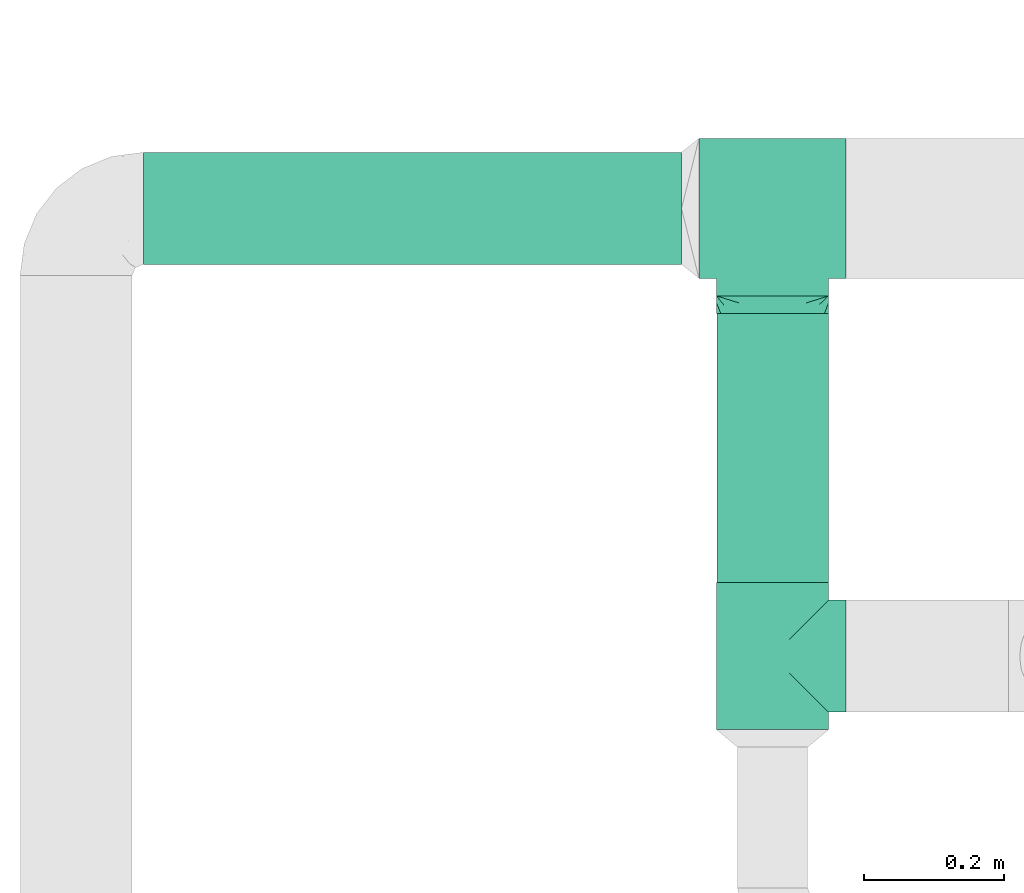
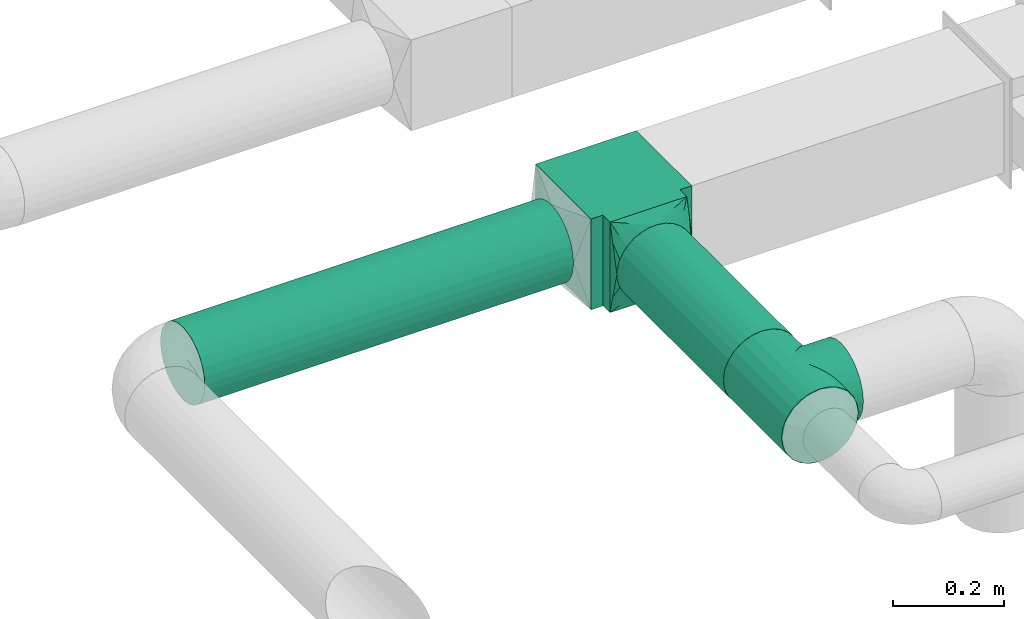
# One storey, part 4 of 12: 3 flow fittings, 2 flow segments.
"""IFC2X3 building model written with IfcOpenShell, lengths in millimetres."""

import ifcopenshell
import ifcopenshell.guid

model = None  # the IFC model being written
_history = None  # IfcOwnerHistory: only IFC2X3 demands one
_inside = {}  # id of a spatial element -> (the spatial element, [elements in it])
_under = {}  # id of a project, library or spatial element -> (it, [spatial elements below it])
_declared = {}  # id of a project -> (the project, [libraries it declares])
_typed = {}  # id of a type object -> (the type object, [elements of that type])
_made_of = {}  # id of a material, layer set ... -> (it, [elements and type objects made of it])


def new_model(schema):
    """Start an empty IFC model of exactly this schema.

    Asked for "IFC4X3", IfcOpenShell would pick the latest addendum, in which some entities
    have other attributes; the version numbers below select the first issue.
    IFC2X3 requires an IfcOwnerHistory on every rooted entity: one is made here for all.
    """
    global model, _history
    if schema == "IFC4X3":
        model = ifcopenshell.file(schema_version=(4, 3, 0, 0))
    else:
        model = ifcopenshell.file(schema=schema)
    _inside.clear()
    _under.clear()
    _declared.clear()
    _typed.clear()
    _made_of.clear()
    _history = None
    if model.schema == "IFC2X3":
        org = make("IfcOrganization", Name="unknown")
        user = make(
            "IfcPersonAndOrganization",
            ThePerson=make("IfcPerson", FamilyName="unknown"),
            TheOrganization=org,
        )
        app = make(
            "IfcApplication",
            ApplicationDeveloper=org,
            Version="unknown",
            ApplicationFullName="unknown",
            ApplicationIdentifier="unknown",
        )
        _history = make(
            "IfcOwnerHistory",
            OwningUser=user,
            OwningApplication=app,
            ChangeAction="ADDED",
            CreationDate=0,
        )
    return model


def make(cls, **values):
    """One entity of the class cls with the attributes given. An attribute that is None is left unset."""
    return model.create_entity(
        cls, **{name: value for name, value in values.items() if value is not None}
    )


def entity(cls, *values):
    """Any entity or typed value of the class cls, its attributes in the order of the schema. None: left unset."""
    e = model.create_entity(cls)
    for i, value in enumerate(values):
        if value is not None:
            e[i] = value
    return e


def rooted(cls, **values):
    """An entity with a GlobalId (a new one), such as an element, a storey or a relation."""
    return make(cls, GlobalId=ifcopenshell.guid.new(), OwnerHistory=_history, **values)


def si_unit(unit_type, name, prefix=None):
    """IfcSIUnit, for example si_unit("LENGTHUNIT", "METRE", prefix="MILLI")."""
    return make("IfcSIUnit", UnitType=unit_type, Prefix=prefix, Name=name)


def converted_unit(unit_type, name, factor, base, dimensions=None, offset=None):
    """IfcConversionBasedUnit, such as the inch: factor (a typed value) times the base unit."""
    return make(
        "IfcConversionBasedUnit"
        if offset is None
        else "IfcConversionBasedUnitWithOffset",
        ConversionOffset=offset,
        Dimensions=None
        if dimensions is None
        else entity("IfcDimensionalExponents", *dimensions),
        UnitType=unit_type,
        Name=name,
        ConversionFactor=make(
            "IfcMeasureWithUnit", ValueComponent=factor, UnitComponent=base
        ),
    )


def derived_unit(unit_type, elements):
    """IfcDerivedUnit: a product of units, each with its exponent."""
    return make(
        "IfcDerivedUnit",
        Elements=[
            make("IfcDerivedUnitElement", Unit=unit, Exponent=power)
            for unit, power in elements
        ],
        UnitType=unit_type,
    )


def assignment(units):
    """IfcUnitAssignment: the units of a project."""
    return None if units is None else make("IfcUnitAssignment", Units=units)


def point(xyz):
    """IfcCartesianPoint."""
    return None if xyz is None else make("IfcCartesianPoint", Coordinates=xyz)


def direction(xyz):
    """IfcDirection."""
    return None if xyz is None else make("IfcDirection", DirectionRatios=xyz)


def frame(location, z_axis=None, x_axis=None):
    """IfcAxis2Placement3D, a coordinate frame: its origin and axes. An axis left out is left unset."""
    return make(
        "IfcAxis2Placement3D",
        Location=point(location),
        Axis=direction(z_axis),
        RefDirection=direction(x_axis),
    )


def frame_2d(location, x_axis=None):
    """IfcAxis2Placement2D, a coordinate frame in the plane: its origin and x axis."""
    return make(
        "IfcAxis2Placement2D", Location=point(location), RefDirection=direction(x_axis)
    )


def origin():
    """The frame at (0, 0, 0) with its axes left unset."""
    return frame((0.0, 0.0, 0.0))


def origin_2d_with_axis():
    """The frame at (0, 0) in the plane with the x axis (1, 0) written out."""
    return frame_2d((0.0, 0.0), x_axis=(1.0, 0.0))


def place(relative_to, where):
    """IfcLocalPlacement: puts the frame where relative to a parent placement (None: the world)."""
    return make(
        "IfcLocalPlacement", PlacementRelTo=relative_to, RelativePlacement=where
    )


def context(
    kind, dimensions, precision=None, world=None, true_north=None, identifier=None
):
    """IfcGeometricRepresentationContext, for example the 3D "Model" context."""
    return make(
        "IfcGeometricRepresentationContext",
        ContextIdentifier=identifier,
        ContextType=kind,
        CoordinateSpaceDimension=dimensions,
        Precision=precision,
        WorldCoordinateSystem=world,
        TrueNorth=true_north,
    )


def subcontext(parent, identifier, kind, view, scale=None):
    """IfcGeometricRepresentationSubContext, for example "Body" below "Model"."""
    return make(
        "IfcGeometricRepresentationSubContext",
        ContextIdentifier=identifier,
        ContextType=kind,
        ParentContext=parent,
        TargetScale=scale,
        TargetView=view,
    )


def project(units=None, contexts=None):
    """IfcProject with its units and contexts."""
    return rooted(
        "IfcProject",
        Name="project",
        RepresentationContexts=contexts,
        UnitsInContext=assignment(units),
    )


def spatial(cls, under=None, at=None, **own):
    """A site, building, storey or space (cls), placed at a placement, below another one or the project."""
    s = rooted(cls, ObjectPlacement=at, **own)
    if under is not None:
        _under.setdefault(under.id(), (under, []))[1].append(s)
    return s


def polyline(points):
    """IfcPolyline through the points."""
    return make("IfcPolyline", Points=[point(p) for p in points])


def profile(cls, at=None, kind="AREA", **sizes):
    """A parametric profile (cls). Its sizes go by their IFC names, for example OverallWidth=200.0."""
    return make(cls, ProfileType=kind, Position=at, **sizes)


def circle(**sizes):
    """IfcCircleProfileDef."""
    return profile("IfcCircleProfileDef", **sizes)


def outline(outer, holes=None, kind="AREA"):
    """IfcArbitraryClosedProfileDef: a profile drawn as a closed curve; with holes, ...WithVoids."""
    if holes is None:
        return make("IfcArbitraryClosedProfileDef", ProfileType=kind, OuterCurve=outer)
    return make(
        "IfcArbitraryProfileDefWithVoids",
        ProfileType=kind,
        OuterCurve=outer,
        InnerCurves=holes,
    )


def extrude(swept, where, along, depth):
    """IfcExtrudedAreaSolid: the profile swept, set in the frame where, extruded along a direction by depth."""
    return make(
        "IfcExtrudedAreaSolid",
        SweptArea=swept,
        Position=where,
        ExtrudedDirection=direction(along),
        Depth=depth,
    )


def faces_of(points, faces, orient=None, outer=None):
    """IfcFace entities. A face is a list of loops; a loop is a list of indices into points, from 0.

    orient and outer hold one flag for each loop. By default every Orientation is true, the
    first loop of a face is its IfcFaceOuterBound and the others are IfcFaceBound.
    """
    made = []
    for i, loops in enumerate(faces):
        bounds = []
        for j, loop in enumerate(loops):
            is_outer = j == 0 if outer is None else outer[i][j]
            bounds.append(
                make(
                    "IfcFaceOuterBound" if is_outer else "IfcFaceBound",
                    Bound=make("IfcPolyLoop", Polygon=[points[k] for k in loop]),
                    Orientation=True if orient is None else orient[i][j],
                )
            )
        made.append(make("IfcFace", Bounds=bounds))
    return made


def faceted_brep(points, faces, orient=None, outer=None, voids=None):
    """IfcFacetedBrep: a solid bounded by flat faces; with voids (closed shells), ...WithVoids."""
    shared = [point(p) for p in points]
    hull = make("IfcClosedShell", CfsFaces=faces_of(shared, faces, orient, outer))
    if voids is None:
        return make("IfcFacetedBrep", Outer=hull)
    return make(
        "IfcFacetedBrepWithVoids",
        Outer=hull,
        Voids=[
            make(cls, CfsFaces=faces_of(shared, fs, o, b)) for cls, fs, o, b in voids
        ],
    )


def shape(context_of_items, identifier, shape_type, items):
    """IfcShapeRepresentation: the items that make up one representation, for example the "Body"."""
    return make(
        "IfcShapeRepresentation",
        ContextOfItems=context_of_items,
        RepresentationIdentifier=identifier,
        RepresentationType=shape_type,
        Items=items,
    )


def source(mapping_origin, context_of_items, identifier, shape_type, items):
    """IfcRepresentationMap: a shape defined once, which mapped items show again and again."""
    return make(
        "IfcRepresentationMap",
        MappingOrigin=mapping_origin,
        MappedRepresentation=shape(context_of_items, identifier, shape_type, items),
    )


def transform(
    local_origin,
    x_axis=None,
    y_axis=None,
    z_axis=None,
    scale=None,
    scale2=None,
    scale3=None,
    uniform=True,
):
    """IfcCartesianTransformationOperator3D, or its non-uniform kind. x_axis, y_axis, z_axis: its Axis1, 2, 3."""
    if uniform:
        return make(
            "IfcCartesianTransformationOperator3D",
            Axis1=direction(x_axis),
            Axis2=direction(y_axis),
            LocalOrigin=point(local_origin),
            Scale=scale,
            Axis3=direction(z_axis),
        )
    return make(
        "IfcCartesianTransformationOperator3DnonUniform",
        Axis1=direction(x_axis),
        Axis2=direction(y_axis),
        LocalOrigin=point(local_origin),
        Scale=scale,
        Axis3=direction(z_axis),
        Scale2=scale2,
        Scale3=scale3,
    )


def mapped(mapping_source, mapping_target):
    """IfcMappedItem: shows the shape of a source again, moved by a transform."""
    return make(
        "IfcMappedItem", MappingSource=mapping_source, MappingTarget=mapping_target
    )


def material(Name=None, Category=None):
    """IfcMaterial."""
    return make("IfcMaterial", Name=Name, Category=Category)


def made_of(thing, what):
    """Note that an element or type object is made of a material, layer set ...; save() writes the relation."""
    if what is not None:
        _made_of.setdefault(what.id(), (what, []))[1].append(thing)
    return thing


def type_object(cls, material=None, **own):
    """A type object (cls), such as IfcWallType, which elements share."""
    return made_of(rooted(cls, **own), material)


def type_shapes(of_type, sources):
    """Give a type object the sources (RepresentationMaps) that its elements show as mapped items."""
    of_type.RepresentationMaps = sources


def element(
    cls,
    number,
    at=None,
    inside=None,
    cuts=None,
    type_object=None,
    material=None,
    context=None,
    identifier="Body",
    shape_type=None,
    held_by="IfcProductDefinitionShape",
    body=None,
    shapes=None,
    **own,
):
    """One element of the class cls, such as IfcWall. Its Tag is "e" and its number.

    at: its placement. inside: the storey or other place that contains it. cuts: it is an
    opening in that element (IfcRelVoidsElement). A single representation is given by context,
    identifier, shape_type and body (its items); several are given by shapes. held_by: the class
    of the entity that holds the representations. save() writes the other relations.
    """
    e = rooted(cls, Tag="e%d" % number, ObjectPlacement=at, **own)
    if body is not None:
        shapes = [shape(context, identifier, shape_type, body)]
    if shapes is not None:
        e.Representation = make(held_by, Representations=shapes)
    if inside is not None:
        _inside.setdefault(inside.id(), (inside, []))[1].append(e)
    if cuts is not None:
        rooted(
            "IfcRelVoidsElement", RelatingBuildingElement=cuts, RelatedOpeningElement=e
        )
    if type_object is not None:
        _typed.setdefault(type_object.id(), (type_object, []))[1].append(e)
    return made_of(e, material)


def aggregate(whole, parts):
    """IfcRelAggregates: a whole, such as a stair, and the parts it consists of."""
    return rooted("IfcRelAggregates", RelatingObject=whole, RelatedObjects=parts)


def save(model, path):
    """Write the relations noted so far, then the file.

    IfcRelAggregates (storeys below a building ...), IfcRelContainedInSpatialStructure (elements
    in a storey), IfcRelDefinesByType, IfcRelAssociatesMaterial and IfcRelDeclares: one each for
    every whole, place, type object, material and project.
    """
    for whole, parts in _under.values():
        aggregate(whole, parts)
    for where, things in _inside.values():
        rooted(
            "IfcRelContainedInSpatialStructure",
            RelatedElements=things,
            RelatingStructure=where,
        )
    for kind, things in _typed.values():
        rooted("IfcRelDefinesByType", RelatedObjects=things, RelatingType=kind)
    for what, things in _made_of.values():
        rooted("IfcRelAssociatesMaterial", RelatedObjects=things, RelatingMaterial=what)
    for by, libraries in _declared.values():
        rooted("IfcRelDeclares", RelatingContext=by, RelatedDefinitions=libraries)
    model.write(path)


model = new_model("IFC2X3")

# Units and contexts
model_context = context("Model", 3, precision=0.01, world=origin(), true_north=direction((6.12303176911189e-17, 1.0)))
body_context = subcontext(model_context, "Body", "Model", "MODEL_VIEW")
ifc_project = project(units=[si_unit("LENGTHUNIT", "METRE", prefix="MILLI"), si_unit("AREAUNIT", "SQUARE_METRE"), si_unit("VOLUMEUNIT", "CUBIC_METRE"), converted_unit("PLANEANGLEUNIT", "DEGREE", entity("IfcRatioMeasure", 0.0174532925199433), si_unit("PLANEANGLEUNIT", "RADIAN"), dimensions=[0, 0, 0, 0, 0, 0, 0]), si_unit("MASSUNIT", "GRAM", prefix="KILO"), derived_unit("MASSDENSITYUNIT", [(si_unit("MASSUNIT", "GRAM", prefix="KILO"), 1), (si_unit("LENGTHUNIT", "METRE"), -3)]), si_unit("TIMEUNIT", "SECOND"), si_unit("FREQUENCYUNIT", "HERTZ"), si_unit("THERMODYNAMICTEMPERATUREUNIT", "DEGREE_CELSIUS"), derived_unit("THERMALTRANSMITTANCEUNIT", [(si_unit("MASSUNIT", "GRAM", prefix="KILO"), 1), (si_unit("THERMODYNAMICTEMPERATUREUNIT", "KELVIN"), -1), (si_unit("TIMEUNIT", "SECOND"), -3)]), derived_unit("VOLUMETRICFLOWRATEUNIT", [(si_unit("LENGTHUNIT", "METRE"), 3), (si_unit("TIMEUNIT", "SECOND"), -1)]), si_unit("ELECTRICCURRENTUNIT", "AMPERE"), si_unit("ELECTRICVOLTAGEUNIT", "VOLT"), si_unit("POWERUNIT", "WATT"), si_unit("FORCEUNIT", "NEWTON", prefix="KILO"), si_unit("ILLUMINANCEUNIT", "LUX"), si_unit("LUMINOUSFLUXUNIT", "LUMEN"), si_unit("LUMINOUSINTENSITYUNIT", "CANDELA"), derived_unit("USERDEFINED", [(si_unit("MASSUNIT", "GRAM", prefix="KILO"), -1), (si_unit("LENGTHUNIT", "METRE"), -2), (si_unit("TIMEUNIT", "SECOND"), 3), (si_unit("LUMINOUSFLUXUNIT", "LUMEN"), 1)]), derived_unit("LINEARVELOCITYUNIT", [(si_unit("LENGTHUNIT", "METRE"), 1), (si_unit("TIMEUNIT", "SECOND"), -1)]), si_unit("PRESSUREUNIT", "PASCAL"), derived_unit("USERDEFINED", [(si_unit("LENGTHUNIT", "METRE"), -2), (si_unit("MASSUNIT", "GRAM", prefix="KILO"), 1), (si_unit("TIMEUNIT", "SECOND"), -2)])], contexts=[model_context])

# Site, building, storey
site_placement = place(None, origin())
site = spatial("IfcSite", under=ifc_project, at=site_placement, CompositionType="ELEMENT")
building_placement = place(site_placement, origin())
building = spatial("IfcBuilding", under=site, at=building_placement, CompositionType="ELEMENT")
storey_placement = place(building_placement, frame((0.0, 0.0, 8000.0)))
storey = spatial("IfcBuildingStorey", under=building, at=storey_placement, Name="02 Level", CompositionType="ELEMENT", Elevation=8000.0)

# Flow segments
duct_segment_type = type_object("IfcDuctSegmentType", Name="Round Duct:Air", PredefinedType="NOTDEFINED")
flow_segment_1_placement = place(storey_placement, frame((22287.748982204, -69237.6305015531, 2918.40472776409)))
element("IfcFlowSegment", 1, at=flow_segment_1_placement, inside=storey, type_object=duct_segment_type, Name="Round Duct:Air", ObjectType="Round Duct:Air", context=body_context, shape_type="SweptSolid", body=[
    extrude(circle(Radius=80.0, at=origin_2d_with_axis()), frame((0.0, 81.595272235915, 81.595272235915), z_axis=(1.0, 0.0, 0.0), x_axis=(0.0, -1.0, 0.0)), (0.0, 0.0, 1.0), 768.241088647822),
])
flow_segment_2_placement = place(storey_placement, frame((23104.3947986159, -69690.234231492, 2918.40472776409)))
element("IfcFlowSegment", 2, at=flow_segment_2_placement, inside=storey, type_object=duct_segment_type, Name="Round Duct:Air", ObjectType="Round Duct:Air", context=body_context, shape_type="SweptSolid", body=[
    extrude(circle(Radius=80.0, at=origin_2d_with_axis()), frame((81.595272235915, 0.0, 81.595272235915), z_axis=(0.0, 1.0, 0.0), x_axis=(1.0, 0.0, 0.0)), (0.0, 0.0, 1.0), 384.199002174792),
])

# Flow fittings
duct_fitting_type_1 = type_object("IfcDuctFittingType", Name="Air_Tee 90_Circ", PredefinedType="NOTDEFINED")
shared_shape_1 = source(origin(), body_context, "Body", "Brep", [
    faceted_brep([(-105.0, 40.0, -69.2820323027551), (-105.0, 20.705523608202, -77.2740661031254), (-105.0, 0.0, -80.0), (-105.0, -20.7055236082013, -77.2740661031255), (-105.0, -40.0, -69.2820323027552), (-105.0, -48.2842712474615, -62.9252873988396), (-105.0, -56.5685424949234, -56.5685424949239), (-105.0, -62.9252873988391, -48.2842712474621), (-105.0, -69.2820323027547, -40.0), (-105.0, -73.2780492029399, -30.352761804101), (-105.0, -75.2760576530325, -25.5291427061515), (-105.0, -77.2740661031251, -20.7055236082019), (-105.0, -77.9555495773438, -15.5291427061515), (-105.0, -78.6370330515624, -10.3527618041011), (-105.0, -79.3185165257811, -5.17638090205062), (-105.0, -80.0, 0.0), (-105.0, -79.3185165257812, 5.17638090205005), (-105.0, -78.6370330515626, 10.3527618041003), (-105.0, -77.955549577344, 15.5291427061506), (-105.0, -77.2740661031254, 20.7055236082009), (-105.0, -75.2760576530329, 25.5291427061505), (-105.0, -73.2780492029403, 30.3527618041001), (-105.0, -69.2820323027552, 40.0), (-105.0, -62.9252873988397, 48.2842712474612), (-105.0, -56.5685424949241, 56.5685424949232), (-105.0, -48.2842712474623, 62.925287398839), (-105.0, -40.0, 69.2820323027547), (-105.0, -20.7055236082022, 77.2740661031253), (-105.0, 0.0, 80.0), (-105.0, 20.7055236082011, 77.2740661031257), (-105.0, 40.0, 69.2820323027556), (-105.0, 56.5685424949234, 56.5685424949245), (-105.0, 69.2820323027549, 40.0), (-105.0, 77.2740661031255, 20.7055236082026), (-105.0, 80.0, 0.0), (-105.0, 77.2740661031257, -20.7055236082016), (-105.0, 69.2820323027554, -40.0), (-105.0, 56.5685424949241, -56.5685424949238), (105.0, 0.0, -80.0), (105.0, 20.7055236082014, -77.2740661031254), (105.0, 40.0, -69.2820323027551), (105.0, 56.5685424949235, -56.5685424949238), (105.0, 69.2820323027547, -40.0), (105.0, 77.2740661031251, -20.7055236082016), (105.0, 80.0, 0.0), (105.0, 77.2740661031248, 20.7055236082026), (105.0, 69.2820323027542, 40.0), (105.0, 56.5685424949228, 56.5685424949245), (105.0, 40.0, 69.2820323027556), (105.0, 20.7055236082004, 77.2740661031257), (105.0, 0.0, 80.0), (105.0, -20.7055236082029, 77.2740661031253), (105.0, -40.0, 69.2820323027547), (105.0, -48.284271247463, 62.9252873988389), (105.0, -56.5685424949248, 56.5685424949232), (105.0, -62.9252873988403, 48.2842712474612), (105.0, -69.2820323027559, 40.0), (105.0, -73.278049202941, 30.3527618041001), (105.0, -75.2760576530335, 25.5291427061505), (105.0, -77.2740661031261, 20.7055236082009), (105.0, -77.9555495773447, 15.5291427061506), (105.0, -78.6370330515632, 10.3527618041003), (105.0, -79.3185165257818, 5.17638090205001), (105.0, -80.0, 0.0), (105.0, -79.3185165257817, -5.17638090205064), (105.0, -78.6370330515631, -10.3527618041011), (105.0, -77.9555495773445, -15.5291427061515), (105.0, -77.2740661031258, -20.7055236082019), (105.0, -75.2760576530332, -25.5291427061515), (105.0, -73.2780492029406, -30.352761804101), (105.0, -69.2820323027554, -40.0), (105.0, -62.9252873988397, -48.2842712474621), (105.0, -56.5685424949241, -56.5685424949239), (105.0, -48.2842712474622, -62.9252873988395), (105.0, -40.0, -69.2820323027552), (105.0, -20.7055236082019, -77.2740661031255), (78.227899039511, -78.2278990395113, 16.7450234954769), (78.6709242796332, -78.6709242796336, 12.5587676216076), (79.1139495197555, -79.1139495197558, 8.37251174773832), (76.9834675239615, -76.9834675239618, 20.5993372484815), (75.7390360084121, -75.7390360084124, 24.4536510014862), (-78.227899039511, -78.2278990395108, 16.7450234954769), (-76.9834675239616, -76.9834675239614, 20.5993372484815), (-75.7390360084121, -75.7390360084119, 24.4536510014861), (73.2501729773131, -73.2501729773134, 32.1622785074954), (56.6842556369154, -56.6842556369157, 56.452592171563), (61.2529055661489, -61.2529055661492, 50.9613067090927), (46.3970120620784, -46.3970120620786, 65.1714452172986), (65.8215554953824, -65.8215554953827, 45.4700212466224), (69.5358642363477, -69.5358642363481, 38.8161498770589), (-73.2501729773132, -73.250172977313, 32.1622785074954), (-78.6709242796333, -78.6709242796331, 12.5587676216076), (-79.5569747598778, -79.5569747598776, 4.18625587386907), (-79.1139495197555, -79.1139495197553, 8.37251174773832), (-46.3970120620785, -46.3970120620784, 65.1714452172985), (-56.6842556369155, -56.6842556369154, 56.452592171563), (-61.252905566149, -61.2529055661488, 50.9613067090927), (-65.8215554953824, -65.8215554953822, 45.4700212466225), (-80.0, -80.0, 0.0), (79.5569747598777, -79.5569747598781, 4.18625587386903), (80.0, -80.0, 0.0), (-35.3477594379945, -35.3477594379945, 71.7672341860383), (-69.5358642363478, -69.5358642363476, 38.8161498770589), (35.3477594379944, -35.3477594379946, 71.7672341860384), (11.9716475671883, -11.9716475671884, 79.0991760673083), (23.8067106814643, -23.8067106814644, 76.3756540170299), (0.0, 0.0, 80.0), (-11.9716475671884, -11.9716475671884, 79.0991760673083), (-23.8067106814644, -23.8067106814643, 76.3756540170299), (-61.2529055661488, -61.2529055661486, -50.9613067090929), (-79.5569747598777, -79.5569747598776, -4.18625587386946), (79.5569747598777, -79.5569747598781, -4.18625587386948), (-75.739036008412, -75.7390360084118, -24.4536510014865), (-76.9834675239615, -76.9834675239613, -20.5993372484819), (-78.2278990395109, -78.2278990395108, -16.7450234954772), (0.0, 0.0, -80.0), (-79.1139495197555, -79.1139495197553, -8.3725117477387), (11.971647567188, -11.9716475671882, -79.0991760673083), (-11.9716475671881, -11.9716475671881, -79.0991760673083), (23.806710681464, -23.8067106814643, -76.3756540170299), (-65.8215554953822, -65.8215554953821, -45.4700212466227), (46.3970120620782, -46.3970120620784, -65.1714452172987), (65.8215554953821, -65.8215554953824, -45.4700212466228), (61.2529055661487, -61.252905566149, -50.961306709093), (79.1139495197555, -79.1139495197558, -8.37251174773877), (78.6709242796332, -78.6709242796335, -12.558767621608), (75.7390360084119, -75.7390360084122, -24.4536510014866), (-73.250172977313, -73.2501729773128, -32.1622785074957), (-56.6842556369153, -56.6842556369152, -56.4525921715632), (-46.3970120620782, -46.3970120620781, -65.1714452172987), (-23.8067106814641, -23.8067106814641, -76.37565401703), (-35.3477594379943, -35.3477594379942, -71.7672341860385), (35.3477594379942, -35.3477594379944, -71.7672341860385), (56.6842556369152, -56.6842556369155, -56.4525921715632), (78.2278990395109, -78.2278990395112, -16.7450234954773), (76.9834675239614, -76.9834675239618, -20.5993372484819), (-69.5358642363476, -69.5358642363474, -38.8161498770592), (73.250172977313, -73.2501729773133, -32.1622785074958), (-78.6709242796332, -78.670924279633, -12.5587676216079), (69.5358642363476, -69.5358642363478, -38.8161498770593), (0.0, -105.0, -80.0), (20.7055236082017, -105.0, -77.2740661031254), (40.0, -105.0, -69.2820323027551), (56.5685424949238, -105.0, -56.5685424949238), (69.2820323027551, -105.0, -40.0), (73.2780492029403, -105.0, -30.3527618041008), (77.2740661031254, -105.0, -20.7055236082016), (78.6370330515627, -105.0, -10.3527618041008), (80.0, -105.0, 0.0), (78.6370330515626, -105.0, 10.3527618041016), (77.2740661031252, -105.0, 20.7055236082026), (73.2780492029399, -105.0, 30.3527618041017), (69.2820323027546, -105.0, 40.0), (56.5685424949231, -105.0, 56.5685424949245), (40.0, -105.0, 69.2820323027556), (20.7055236082008, -105.0, 77.2740661031257), (0.0, -105.0, 80.0), (-20.7055236082025, -105.0, 77.2740661031253), (-40.0, -105.0, 69.2820323027547), (-56.5685424949244, -105.0, 56.5685424949232), (-69.2820323027555, -105.0, 40.0), (-73.2780492029406, -105.0, 30.3527618041001), (-77.2740661031257, -105.0, 20.7055236082009), (-78.6370330515629, -105.0, 10.3527618041003), (-80.0, -105.0, 0.0), (-78.6370330515627, -105.0, -10.352761804101), (-77.2740661031254, -105.0, -20.7055236082019), (-73.2780492029402, -105.0, -30.352761804101), (-69.282032302755, -105.0, -40.0), (-56.5685424949237, -105.0, -56.5685424949239), (-40.0, -105.0, -69.2820323027552), (-20.7055236082016, -105.0, -77.2740661031255)], [[[0, 1, 2, 3, 4, 5, 6, 7, 8, 9, 10, 11, 12, 13, 14, 15, 16, 17, 18, 19, 20, 21, 22, 23, 24, 25, 26, 27, 28, 29, 30, 31, 32, 33, 34, 35, 36, 37]], [[38, 39, 40, 41, 42, 43, 44, 45, 46, 47, 48, 49, 50, 51, 52, 53, 54, 55, 56, 57, 58, 59, 60, 61, 62, 63, 64, 65, 66, 67, 68, 69, 70, 71, 72, 73, 74, 75]], [[60, 59, 76]], [[77, 60, 76]], [[62, 61, 78]], [[79, 76, 59, 80]], [[19, 81, 82, 83]], [[57, 56, 84]], [[54, 85, 86]], [[87, 53, 52]], [[80, 57, 84]], [[88, 55, 86]], [[85, 54, 53]], [[85, 53, 87]], [[56, 88, 89, 84]], [[57, 80, 59, 58]], [[90, 21, 83]], [[91, 81, 18]], [[16, 92, 93]], [[54, 86, 55]], [[61, 77, 78]], [[20, 19, 83, 21]], [[81, 19, 18]], [[88, 56, 55]], [[94, 25, 95]], [[24, 23, 96]], [[97, 23, 22]], [[95, 25, 24]], [[92, 15, 98]], [[63, 99, 100]], [[26, 94, 101]], [[97, 22, 90, 102]], [[99, 63, 62]], [[23, 97, 96]], [[87, 52, 103]], [[51, 50, 104]], [[18, 17, 91]], [[105, 103, 51]], [[104, 105, 51]], [[24, 96, 95]], [[104, 50, 106]], [[107, 106, 28]], [[51, 103, 52]], [[32, 31, 47, 46]], [[33, 32, 46, 45]], [[30, 29, 49, 48]], [[31, 30, 48, 47]], [[49, 29, 28, 106, 50]], [[34, 33, 45, 44]], [[90, 22, 21]], [[108, 107, 27]], [[108, 27, 101]], [[27, 107, 28]], [[17, 93, 91]], [[101, 27, 26]], [[94, 26, 25]], [[15, 92, 16]], [[62, 78, 99]], [[93, 17, 16]], [[60, 77, 61]], [[6, 109, 7]], [[15, 110, 98]], [[111, 63, 100]], [[11, 112, 113, 114]], [[112, 11, 10, 9]], [[41, 37, 36, 42]], [[36, 35, 43, 42]], [[0, 37, 41, 40]], [[34, 44, 43, 35]], [[115, 2, 1, 39, 38]], [[14, 116, 110]], [[117, 38, 75]], [[110, 15, 14]], [[117, 115, 38]], [[2, 115, 118]], [[119, 117, 75]], [[120, 8, 7]], [[121, 74, 73]], [[40, 39, 1, 0]], [[71, 122, 123]], [[65, 124, 125]], [[126, 69, 68, 67]], [[124, 65, 64]], [[112, 9, 127]], [[128, 5, 129]], [[130, 131, 3]], [[118, 130, 3]], [[2, 118, 3]], [[131, 4, 3]], [[119, 75, 132]], [[72, 133, 73]], [[67, 134, 135, 126]], [[121, 73, 133]], [[72, 71, 123]], [[8, 120, 136, 127]], [[71, 70, 122]], [[74, 121, 132]], [[111, 124, 64]], [[137, 69, 126]], [[66, 125, 134]], [[138, 12, 114]], [[63, 111, 64]], [[70, 137, 139, 122]], [[13, 138, 116]], [[137, 70, 69]], [[66, 65, 125]], [[128, 6, 5]], [[129, 4, 131]], [[129, 5, 4]], [[109, 120, 7]], [[109, 6, 128]], [[72, 123, 133]], [[134, 67, 66]], [[14, 13, 116]], [[127, 9, 8]], [[11, 114, 12]], [[12, 138, 13]], [[74, 132, 75]], [[140, 141, 142, 143, 144, 145, 146, 147, 148, 149, 150, 151, 152, 153, 154, 155, 156, 157, 158, 159, 160, 161, 162, 163, 164, 165, 166, 167, 168, 169, 170, 171]], [[163, 162, 81]], [[164, 93, 92, 98]], [[164, 163, 93]], [[162, 90, 83, 82, 81]], [[159, 158, 94]], [[97, 160, 159]], [[90, 162, 161, 160]], [[101, 158, 157]], [[163, 81, 91, 93]], [[160, 97, 102, 90]], [[94, 95, 159]], [[159, 95, 96, 97]], [[108, 101, 157]], [[156, 106, 107]], [[108, 157, 107]], [[94, 158, 101]], [[84, 152, 151, 150]], [[107, 157, 156]], [[154, 103, 155]], [[155, 104, 156]], [[87, 154, 153]], [[148, 100, 99, 78]], [[153, 152, 88]], [[149, 78, 77, 76]], [[87, 103, 154]], [[105, 104, 155]], [[103, 105, 155]], [[150, 76, 79, 80, 84]], [[76, 150, 149]], [[153, 88, 86, 85]], [[148, 78, 149]], [[152, 84, 89, 88]], [[87, 153, 85]], [[156, 104, 106]], [[147, 146, 134]], [[127, 168, 167, 166]], [[148, 147, 124]], [[146, 137, 126, 135, 134]], [[137, 146, 145, 144]], [[147, 134, 125, 124]], [[122, 144, 143]], [[148, 124, 111, 100]], [[143, 142, 121]], [[132, 142, 141]], [[144, 122, 139, 137]], [[121, 133, 143]], [[143, 133, 123, 122]], [[119, 132, 141]], [[140, 115, 117]], [[119, 141, 117]], [[121, 142, 132]], [[164, 116, 165]], [[117, 141, 140]], [[170, 131, 171]], [[171, 118, 140]], [[129, 170, 169]], [[164, 98, 110, 116]], [[169, 168, 120]], [[165, 116, 138, 114]], [[129, 131, 170]], [[130, 118, 171]], [[131, 130, 171]], [[114, 166, 165]], [[166, 114, 113, 112, 127]], [[169, 120, 109, 128]], [[168, 127, 136, 120]], [[129, 169, 128]], [[140, 118, 115]]]),
])
type_shapes(duct_fitting_type_1, [shared_shape_1])
flow_fitting_1_placement = place(storey_placement, frame((23185.9900708518, -69795.234231492, 3000.0), z_axis=(0.0, 0.0, 1.0), x_axis=(0.0, 1.0, 0.0)))
element("IfcFlowFitting", 3, at=flow_fitting_1_placement, inside=storey, type_object=duct_fitting_type_1, Name="tee_90_001:Air_Tee 90_Circ", ObjectType="tee_90_001:Air_Tee 90_Circ", context=body_context, shape_type="MappedRepresentation", body=[
    mapped(shared_shape_1, transform((0.0, 0.0, 0.0), scale=1.0)),
])
duct_fitting_type_2 = type_object("IfcDuctFittingType", Name="Air_Rect", PredefinedType="NOTDEFINED")
shared_shape_2 = source(origin(), body_context, "Body", "SweptSolid", [
    extrude(outline(polyline([(-105.0, 43.7500000000001), (-105.0, -156.25), (105.0, -156.25), (105.0, 43.75), (80.0, 43.75), (80.0, 68.7499999999997), (-80.0, 68.7500000000002), (-80.0, 43.7500000000001), (-105.0, 43.7500000000001)])), frame((0.0, -56.25, -100.0), z_axis=(0.0, 0.0, -1.0), x_axis=(1.0, 0.0, 0.0)), (0.0, 0.0, -1.0), 200.0),
])
type_shapes(duct_fitting_type_2, [shared_shape_2])
flow_fitting_2_placement = place(storey_placement, frame((23185.9900708518, -69156.0352293172, 3000.0)))
element("IfcFlowFitting", 4, at=flow_fitting_2_placement, inside=storey, type_object=duct_fitting_type_2, Name="1_001:Air_Rect", ObjectType="1_001:Air_Rect", context=body_context, shape_type="MappedRepresentation", body=[
    mapped(shared_shape_2, transform((0.0, 0.0, 0.0), scale=1.0)),
])
ifc_material = material(Name="Material_Duct")
duct_fitting_type_3 = type_object("IfcDuctFittingType", Name="Air_Multi shape transition_Circ", PredefinedType="NOTDEFINED", material=ifc_material)
shared_shape_3 = source(origin(), body_context, "Body", "Brep", [
    faceted_brep([(25.0, -30.614674589207, -73.9103626009021), (25.0, -22.8665162204521, -75.4515671248636), (25.0, -15.1183578516973, -76.9927716488251), (25.0, -11.3387683887729, -77.7445787366186), (25.0, -7.55917892584856, -78.4963858244121), (25.0, 0.0, -80.0), (25.0, 7.55917891579331, -78.4963858264122), (25.0, 15.1183578315867, -76.9927716528254), (25.0, 18.9924370209918, -76.2221693898446), (25.0, 22.8665162103969, -75.4515671268637), (25.0, 30.6146745892071, -73.9103626009021), (25.0, 37.1031415656363, -69.5749075744073), (25.0, 43.5916085420654, -65.2394525479125), (25.0, 50.0800755184946, -60.9039975214177), (25.0, 56.5685424949238, -56.5685424949229), (25.0, 60.9039975214186, -50.0800755184938), (25.0, 65.2394525479134, -43.5916085420646), (25.0, 69.5749075744082, -37.1031415656355), (25.0, 73.910362600903, -30.6146745892063), (25.0, 75.4515671248645, -22.8665162204514), (25.0, 76.992771648826, -15.1183578516966), (25.0, 77.7445787366195, -11.3387683887722), (25.0, 78.496385824413, -7.55917892584782), (25.0, 80.0, 0.0), (25.0, 78.4963858264131, 7.55917891579322), (25.0, 76.9927716528263, 15.1183578315867), (25.0, 76.2221693898455, 18.9924370209917), (25.0, 75.4515671268647, 22.8665162103968), (25.0, 73.910362600903, 30.614674589207), (25.0, 69.5749075744082, 37.1031415656362), (25.0, 65.2394525479135, 43.5916085420653), (25.0, 60.9039975214187, 50.0800755184945), (25.0, 56.5685424949239, 56.5685424949237), (25.0, 50.0800755184948, 60.9039975214185), (25.0, 43.5916085420656, 65.2394525479133), (25.0, 37.1031415656365, 69.5749075744081), (25.0, 30.6146745892073, 73.9103626009029), (25.0, 22.8665162204525, 75.4515671248644), (25.0, 15.1183578516976, 76.992771648826), (25.0, 11.3387683887732, 77.7445787366195), (25.0, 7.55917892584888, 78.496385824413), (25.0, 0.0, 80.0), (25.0, -7.55917891579327, 78.4963858264132), (25.0, -15.1183578315867, 76.9927716528263), (25.0, -18.9924370209918, 76.2221693898455), (25.0, -22.8665162103969, 75.4515671268647), (25.0, -30.6146745892071, 73.910362600903), (25.0, -37.1031415656362, 69.5749075744082), (25.0, -43.5916085420654, 65.2394525479134), (25.0, -50.0800755184946, 60.9039975214187), (25.0, -56.5685424949237, 56.5685424949239), (25.0, -60.9039975214185, 50.0800755184947), (25.0, -65.2394525479133, 43.5916085420656), (25.0, -69.5749075744081, 37.1031415656364), (25.0, -73.9103626009029, 30.6146745892072), (25.0, -75.4515671248645, 22.8665162204524), (25.0, -76.992771648826, 15.1183578516975), (25.0, -77.7445787366195, 11.3387683887731), (25.0, -78.496385824413, 7.55917892584876), (25.0, -80.0, 0.0), (25.0, -78.4963858264131, -7.55917891579276), (25.0, -76.9927716528262, -15.1183578315862), (25.0, -76.2221693898453, -18.9924370209913), (25.0, -75.4515671268645, -22.8665162103963), (25.0, -73.9103626009028, -30.6146745892065), (25.0, -69.574907574408, -37.1031415656356), (25.0, -65.2394525479132, -43.5916085420648), (25.0, -60.9039975214184, -50.0800755184939), (25.0, -56.5685424949236, -56.5685424949231), (25.0, -50.0800755184945, -60.9039975214178), (25.0, -43.5916085420653, -65.2394525479126), (25.0, -37.1031415656362, -69.5749075744073), (0.0, -80.0, 100.0), (0.0, 80.0, 100.0), (0.0, 80.0, -100.0), (0.0, -80.0, -100.0), (6.50713916945186, -59.1771546577547, 94.7942886644397), (9.76070875417778, -48.7657319866316, 92.1914329966587), (22.0035695847259, -9.588577328877, 82.3971443322195), (19.0071391694519, -19.1771546577542, 84.7942886644389), (16.0107087541778, -28.7657319866313, 87.1914329966584), (13.0142783389037, -38.3543093155085, 89.5885773288778), (12.5000000004112, -69.9443399352347, 76.5204921859004), (9.76070845754317, -80.0, 60.9571661698283), (13.0142779433909, -80.0, 47.9428882264372), (16.0107084575432, -80.0, 35.9571661698279), (19.0071389716954, -80.0, 23.9714441132186), (20.5053542287716, -80.0, 17.978583084914), (22.0035694858477, -80.0, 11.9857220566093), (3.25356948584772, -80.0, 86.9857220566105), (6.50713897169544, -80.0, 73.9714441132194), (3.25356958472593, -69.5885773288778, 97.3971443322206), (3.25356958472592, -80.0, -86.9857216610962), (6.50713916945185, -80.0, -73.9714433221924), (9.76070875417777, -80.0, -60.9571649832887), (13.0142783389037, -80.0, -47.9428866443849), (16.0107087541778, -80.0, -35.9571649832885), (19.0071391694518, -80.0, -23.9714433221921), (22.0035695847259, -80.0, -11.9857216610957), (12.5000000004112, -66.5204921862289, -79.9443399349049), (9.76070845754315, -48.7657329358624, -92.1914332339651), (13.0142779433909, -38.3543105811496, -89.5885776452868), (16.0107084575432, -28.7657329358621, -87.1914332339649), (19.0071389716954, -19.1771552905747, -84.794288822643), (20.5053542287716, -14.382866467931, -83.595716616982), (22.0035694858477, -9.58857764528725, -82.397144411321), (3.25356948584772, -69.5885776452881, -97.3971444113217), (6.50713897169543, -59.1771552905752, -94.7942888226434), (3.25356958472593, 69.5885773288765, -97.3971443322191), (6.50713916945186, 59.1771546577536, -94.7942886644383), (9.76070875417778, 48.7657319866307, -92.1914329966574), (13.0142783389037, 38.3543093155078, -89.5885773288765), (16.0107087541778, 28.7657319866308, -87.1914329966572), (19.0071391694519, 19.1771546577538, -84.7942886644378), (22.0035695847259, 9.58857732887686, -82.3971443322185), (12.5000000004112, 69.9443399352339, -76.5204921858991), (9.76070845754317, 80.0, -60.957166169827), (13.0142779433909, 80.0, -47.942888226436), (16.0107084575432, 80.0, -35.9571661698268), (19.0071389716954, 80.0, -23.9714441132175), (20.5053542287716, 80.0, -17.9785830849129), (22.0035694858477, 80.0, -11.9857220566083), (3.25356948584772, 80.0, -86.985722056609), (6.50713897169544, 80.0, -73.971444113218), (3.25356958472593, 80.0, 86.9857216610977), (6.50713916945185, 80.0, 73.9714433221937), (9.76070875417778, 80.0, 60.9571649832898), (13.0142783389037, 80.0, 47.9428866443859), (16.0107087541778, 80.0, 35.9571649832893), (19.0071391694519, 80.0, 23.9714433221928), (22.0035695847259, 80.0, 11.9857216610963), (12.5000000004112, 66.5204921862283, 79.9443399349061), (9.76070845754316, 48.7657329358616, 92.1914332339665), (13.0142779433909, 38.354310581149, 89.5885776452881), (16.0107084575432, 28.7657329358618, 87.191433233966), (19.0071389716954, 19.1771552905745, 84.794288822644), (20.5053542287716, 14.3828664679309, 83.595716616983), (22.0035694858477, 9.58857764528735, 82.397144411322), (3.25356948584772, 69.5885776452868, 97.3971444113232), (6.50713897169544, 59.1771552905742, 94.7942888226448)], [[[0, 1, 2, 3, 4, 5, 6, 7, 8, 9, 10, 11, 12, 13, 14, 15, 16, 17, 18, 19, 20, 21, 22, 23, 24, 25, 26, 27, 28, 29, 30, 31, 32, 33, 34, 35, 36, 37, 38, 39, 40, 41, 42, 43, 44, 45, 46, 47, 48, 49, 50, 51, 52, 53, 54, 55, 56, 57, 58, 59, 60, 61, 62, 63, 64, 65, 66, 67, 68, 69, 70, 71]], [[72, 73, 74, 75]], [[76, 48, 77]], [[48, 47, 46, 77]], [[78, 79, 80, 81, 77, 46, 45, 44, 43, 42, 41]], [[49, 82, 50]], [[56, 55, 54, 83, 84, 85, 86, 87, 88, 59, 58, 57]], [[82, 72, 89]], [[82, 51, 50]], [[83, 52, 90]], [[91, 72, 82]], [[54, 53, 52, 83]], [[90, 52, 51]], [[51, 82, 89]], [[90, 51, 89]], [[76, 49, 48]], [[49, 76, 91]], [[82, 49, 91]], [[88, 87, 86, 85, 84, 83, 90, 89, 72, 75, 92, 93, 94, 95, 96, 97, 98, 59]], [[93, 66, 94]], [[66, 65, 64, 94]], [[98, 97, 96, 95, 94, 64, 63, 62, 61, 60, 59]], [[67, 99, 68]], [[2, 1, 0, 100, 101, 102, 103, 104, 105, 5, 4, 3]], [[99, 75, 106]], [[99, 69, 68]], [[100, 70, 107]], [[92, 75, 99]], [[0, 71, 70, 100]], [[107, 70, 69]], [[69, 99, 106]], [[107, 69, 106]], [[93, 67, 66]], [[67, 93, 92]], [[99, 67, 92]], [[105, 104, 103, 102, 101, 100, 107, 106, 75, 74, 108, 109, 110, 111, 112, 113, 114, 5]], [[109, 12, 110]], [[12, 11, 10, 110]], [[114, 113, 112, 111, 110, 10, 9, 8, 7, 6, 5]], [[13, 115, 14]], [[20, 19, 18, 116, 117, 118, 119, 120, 121, 23, 22, 21]], [[115, 74, 122]], [[115, 15, 14]], [[116, 16, 123]], [[108, 74, 115]], [[18, 17, 16, 116]], [[123, 16, 15]], [[15, 115, 122]], [[123, 15, 122]], [[109, 13, 12]], [[13, 109, 108]], [[115, 13, 108]], [[74, 73, 124, 125, 126, 127, 128, 129, 130, 23, 121, 120, 119, 118, 117, 116, 123, 122]], [[125, 30, 126]], [[30, 29, 28, 126]], [[130, 129, 128, 127, 126, 28, 27, 26, 25, 24, 23]], [[31, 131, 32]], [[38, 37, 36, 132, 133, 134, 135, 136, 137, 41, 40, 39]], [[131, 73, 138]], [[131, 33, 32]], [[132, 34, 139]], [[124, 73, 131]], [[36, 35, 34, 132]], [[139, 34, 33]], [[33, 131, 138]], [[139, 33, 138]], [[125, 31, 30]], [[31, 125, 124]], [[131, 31, 124]], [[73, 72, 91, 76, 77, 81, 80, 79, 78, 41, 137, 136, 135, 134, 133, 132, 139, 138]]]),
])
type_shapes(duct_fitting_type_3, [shared_shape_3])
flow_fitting_3_placement = place(storey_placement, frame((23185.9900708518, -69281.0352293172, 3000.0), z_axis=(0.0, 0.0, 1.0), x_axis=(0.0, -1.0, 0.0)))
element("IfcFlowFitting", 5, at=flow_fitting_3_placement, inside=storey, type_object=duct_fitting_type_3, material=ifc_material, Name="multi_shape_trans_001:Air_Multi shape transition_Circ", ObjectType="multi_shape_trans_001:Air_Multi shape transition_Circ", context=body_context, shape_type="MappedRepresentation", body=[
    mapped(shared_shape_3, transform((0.0, 0.0, 0.0), scale=1.0)),
])

save(model, "model.ifc")
